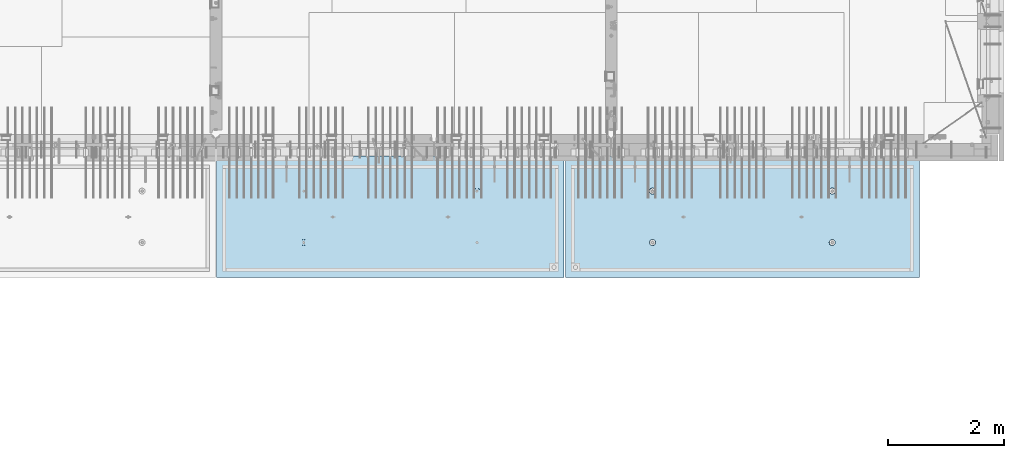
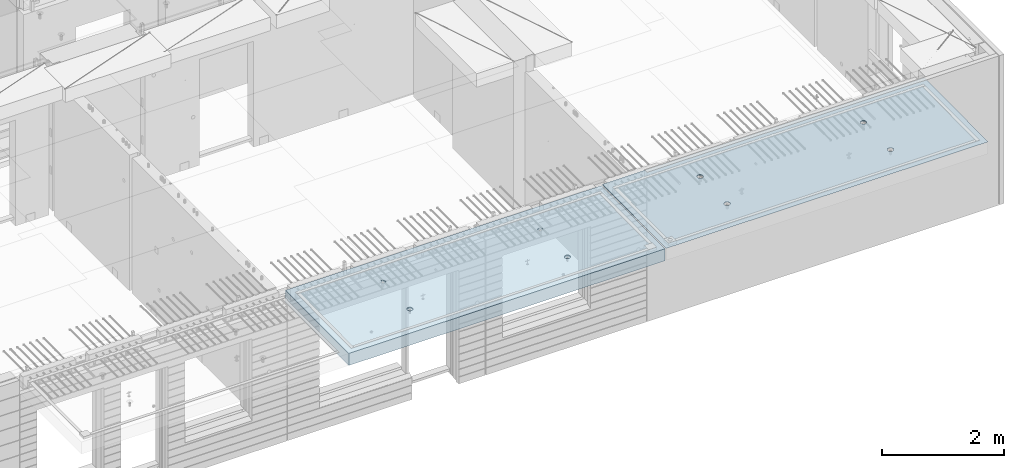
# One storey, part 202 of 349: 2 slabs, 2 elements without a shape of their own.
"""IFC2X3 building model written with IfcOpenShell, lengths in millimetres."""

from ifc_helpers import new_model, si_unit, frame, origin_with_axes, place, context, subcontext, project, spatial, faceted_brep, material, type_object, element, aggregate, save


model = new_model("IFC2X3")

# Units and contexts
model_context = context("Model", 3, precision=1e-05, world=origin_with_axes())
body_context = subcontext(model_context, "Body", "Model", "MODEL_VIEW")
ifc_project = project(units=[si_unit("LENGTHUNIT", "METRE", prefix="MILLI"), si_unit("AREAUNIT", "SQUARE_METRE"), si_unit("VOLUMEUNIT", "CUBIC_METRE"), si_unit("MASSUNIT", "GRAM", prefix="KILO"), si_unit("TIMEUNIT", "SECOND"), si_unit("PLANEANGLEUNIT", "RADIAN"), si_unit("SOLIDANGLEUNIT", "STERADIAN"), si_unit("THERMODYNAMICTEMPERATUREUNIT", "DEGREE_CELSIUS"), si_unit("LUMINOUSINTENSITYUNIT", "LUMEN")], contexts=[model_context])

# Site, building, storey
site_placement = place(None, origin_with_axes())
site = spatial("IfcSite", under=ifc_project, at=site_placement, CompositionType="ELEMENT")
building_placement = place(site_placement, origin_with_axes())
building = spatial("IfcBuilding", under=site, at=building_placement, CompositionType="ELEMENT")
storey_placement = place(building_placement, origin_with_axes())
storey = spatial("IfcBuildingStorey", under=building, at=storey_placement, Name="4", CompositionType="ELEMENT", Elevation=0.0)

# Assembly, slab
assembly_1_placement = place(storey_placement, origin_with_axes())
assembly_1 = element("IfcElementAssembly", 1, at=assembly_1_placement, inside=storey, AssemblyPlace="NOTDEFINED", PredefinedType="REINFORCEMENT_UNIT")
ifc_material = material(Name="CONCRETE/C35/45")
slab_type_1 = type_object("IfcSlabType", PredefinedType="NOTDEFINED")
slab_1_placement = place(assembly_1_placement, frame((33909.9998568133, 7629.99655735226, 93720.0), z_axis=(-1.11800000013248e-06, -0.999999999999375, 0.0), x_axis=(-0.999999999999093, 1.34699999998405e-06, 0.0)))
slab_1 = element("IfcSlab", 2, at=slab_1_placement, type_object=slab_type_1, material=ifc_material, PredefinedType="FLOOR", context=body_context, shape_type="Brep", body=[
    faceted_brep([(4540.5429407651, 4.39872694581572, 1501.06992058926), (4541.14829635528, 10.0, 1500.87322939105), (4548.44394652849, 10.0, 1515.19178906455), (4547.94177529477, 4.5376880098047, 1515.55663695519), (4559.80720044041, 10.0, 1526.55506865745), (4559.44971344555, 4.64790814399021, 1527.04710612474), (4574.1257436257, 10.0, 1533.85075119058), (4573.94028523447, 4.71864591048507, 1534.42153123348), (4589.99797731422, 10.0, 1536.36468442559), (4589.99797663917, 4.74301553473924, 1536.96206902392), (4605.87021668419, 10.0, 1533.85078706184), (4606.05567377324, 4.71864625823218, 1534.42156748629), (4620.18877635769, 10.0, 1526.55513688863), (4620.54626219634, 4.64790880566579, 1527.04717510301), (4631.55205595059, 10.0, 1515.19188297671), (4632.05422627598, 4.53768892097287, 1515.5567319414), (4638.84773848372, 10.0, 1500.87333979142), (4639.45309351355, 4.39872801757883, 1501.0700323201), (4641.36167171873, 10.0, 1485.0011061029), (4642.01569559209, 4.24458991442225, 1485.00110684195), (4638.84777435497, 10.0, 1469.12886673293), (4639.48645790269, 4.09034788147255, 1468.92134666652), (4631.55212418177, 10.0, 1454.81030705943), (4632.10822132771, 3.95111487063696, 1454.40627979329), (4620.18887026985, 10.0, 1443.44702746653), (4620.60028327593, 3.84055859092041, 1442.88076738872), (4605.87032708456, 10.0, 1436.1513449334), (4606.0891136727, 3.76954887632746, 1435.47799164192), (4589.99809339604, 10.0, 1433.63741169839), (4589.99809419923, 3.74507537655882, 1432.92662480936), (4574.12585402606, 10.0, 1436.15130906214), (4573.90706894744, 3.76954852712515, 1435.47795523847), (4559.80729435257, 10.0, 1443.44695923535), (4559.39588258188, 3.84055792690197, 1442.8806981667), (4548.44401475967, 10.0, 1454.81021314727), (4547.88791844284, 3.95111395715503, 1454.40618456334), (4541.14833222653, 10.0, 1469.12875633256), (4540.50964903182, 4.09034680826881, 1468.92123478504), (4538.63439899152, 10.0, 1485.00099002108), (4537.98037499001, 4.24458878673613, 1485.00098928203), (0.0, 10.0, 0.0), (0.0, -10.0, 0.0), (0.000819232023786753, 10.0, 2085.00366210937), (6090.0, 10.0, 1.39971234602854e-09), (6090.0, -10.0, 1.39971234602854e-09), (6090.0009765625, 10.0, 2085.00366210937), (1450.13343574908, -4.39996016312216, 583.805178487186), (1451.68970517172, 10.0, 584.310843019489), (1449.20358093267, 10.0, 600.007498901724), (1447.58488291994, -4.2445425120095, 600.007497072595), (1457.56794425657, -4.54025428339082, 569.17949076172), (1458.90468325205, 10.0, 570.15069079864), (1469.16362510388, -4.65165300057561, 557.566154097598), (1470.14226284945, 10.0, 558.913136598135), (1483.78541952188, -4.72320365252381, 550.106985529351), (1484.30243137612, 10.0, 551.698190519764), (1499.99909477071, -4.74786334385863, 547.536208193364), (1499.99909287695, 10.0, 549.212101755165), (1516.2127641972, -4.72320330067305, 550.107022210277), (1515.69574875919, 10.0, 551.698225994214), (1530.8345417251, -4.65165233150765, 557.566223847243), (1529.85590098004, 10.0, 558.913204074546), (1542.4301962863, -4.54025336292398, 569.179586717545), (1541.09345518054, 10.0, 570.150783671952), (1549.86467170747, -4.39995908172568, 583.805291221456), (1548.30840125891, 10.0, 584.310952198615), (1552.41318790712, -4.24454137573775, 600.00761552858), (1550.79449002351, 10.0, 600.007613699451), (1549.83105300624, -4.08922839167644, 616.199022553535), (1548.30836578447, 10.0, 615.704269581685), (1542.37578967018, -3.94920829200419, 630.796143582923), (1541.09338770413, 10.0, 629.864421802535), (1530.78010888273, -3.83814828256436, 642.374169903326), (1529.85580810672, 10.0, 641.101976003039), (1516.17906941009, -3.76687165064504, 649.804771831361), (1515.69563958006, 10.0, 648.316922081409), (1499.99897631459, -3.74231662515376, 652.364637735232), (1499.99897807923, 10.0, 650.803010846011), (1483.81888899212, -3.76687200104061, 649.804735302227), (1484.30232219699, 10.0, 648.316886606961), (1469.21786628045, -3.83814894927491, 642.374100399286), (1470.14216997614, 10.0, 641.101908526629), (1457.62221161949, -3.94920921009907, 630.796047872702), (1458.90461577564, 10.0, 629.864328929222), (1450.16698124064, -4.08922947161773, 616.198909971055), (1451.68966969727, 10.0, 615.704160402559), (1450.509655854, 4.09040925785666, 1468.92774521603), (1451.1483322995, 10.0, 1469.13526457059), (1448.63439906449, 10.0, 1485.00749825911), (1447.98038215714, 4.24465121529647, 1485.00749752007), (1457.88792425878, 3.95117642574769, 1454.41269697389), (1458.44401483263, 10.0, 1454.8167213853), (1469.39588682837, 3.84062041057041, 1442.8872121491), (1469.80729442553, 10.0, 1443.45346747338), (1483.90707121489, 3.76961102048517, 1435.48447023045), (1484.12585409903, 10.0, 1436.15781730018), (1499.99809427218, 3.74513787325122, 1432.93314014929), (1499.998093469, 10.0, 1433.64391993642), (1516.08911155117, 3.76961136968748, 1435.48450663389), (1515.87032715752, 10.0, 1436.15785317143), (1530.60027917537, 3.8406210745743, 1442.88728137111), (1530.18887034281, 10.0, 1443.45353570456), (1542.1082156577, 3.95117733922962, 1454.41279220383), (1541.55212425473, 10.0, 1454.81681529746), (1549.48645122644, 4.09041033107496, 1468.92785709749), (1548.84777442794, 10.0, 1469.13537497096), (1552.0156885709, 4.24465234298259, 1485.00761507997), (1551.3616717917, 10.0, 1485.00761434093), (1549.45308684185, 4.39879042512621, 1501.07653836665), (1548.84773855669, 10.0, 1500.87984802946), (1542.05422061333, 4.5377513095591, 1515.56323601226), (1541.55205602355, 10.0, 1515.19839121474), (1530.54625810314, 4.64797117923445, 1527.0536776068), (1530.18877643065, 10.0, 1526.56164512666), (1516.05567165627, 4.71870862215292, 1534.42806898436), (1515.87021675715, 10.0, 1533.85729529987), (1499.99797671215, 4.74307789534214, 1536.96857017552), (1499.99797738718, 10.0, 1536.37119266363), (1483.94028749739, 4.71870827439125, 1534.42803273156), (1484.12574369866, 10.0, 1533.85725942862), (1469.44971768469, 4.64797051755886, 1527.05360862854), (1469.80720051337, 10.0, 1526.56157689548), (1457.94178110336, 4.53775039840548, 1515.56314102606), (1458.44394660145, 10.0, 1515.19829730258), (1450.54294758273, 4.39878935334855, 1501.07642663582), (1451.14829642825, 10.0, 1500.87973762909), (4619.85580803376, 10.0, 641.095467765007), (4620.78011297592, -3.83821065611846, 642.367667399533), (4606.17907152706, -3.76693401455123, 649.798270333285), (4605.6956395071, 10.0, 648.310413843377), (4631.09338763116, 10.0, 629.857913564502), (4632.37579533283, -3.94927068060497, 630.789639512066), (4638.30836571149, 10.0, 615.697761343654), (4639.83105967794, -4.08929079922382, 616.192516506986), (4640.79448995054, 10.0, 600.001105461418), (4642.4131949283, -4.24460380429809, 600.001107290555), (4638.30840118594, 10.0, 584.304443960583), (4639.86467838373, -4.40002153132809, 583.798780790478), (4631.09345510758, 10.0, 570.14427543392), (4632.43020195632, -4.54031583151664, 569.173074307006), (4619.85590090707, 10.0, 558.906695836514), (4620.83454582566, -4.65171481517609, 557.559709864858), (4605.69574868622, 10.0, 551.691717756181), (4606.21276631872, -4.72326579401852, 550.100507218302), (4589.99909280399, 10.0, 549.205593517132), (4589.99909469776, -4.74792584055103, 547.529692853434), (4574.30243130315, 10.0, 551.691682281732), (4573.78541725442, -4.72326614588383, 550.10047053737), (4560.14226277649, 10.0, 558.906628360102), (4559.16362085739, -4.65171548424405, 557.559640115202), (4548.90468317908, 10.0, 570.144182560607), (4547.56793844064, -4.54031675198348, 569.172978351166), (4541.68970509875, 10.0, 584.304334781456), (4540.1334289269, -4.40002261272457, 583.798668056191), (4547.6222058109, -3.9492715986853, 630.789543801832), (4559.21786204131, -3.83821132282901, 642.367597895483), (4573.8188867292, -3.76693436496134, 649.798233804147), (4589.99897624161, -3.74237898574211, 652.358136583629), (4537.58487575281, -4.2446049405844, 600.000988834554), (4540.166974423, -4.0892918791651, 616.192403924491), (4589.99897800626, 10.0, 650.796502607977), (4574.30232212402, 10.0, 648.310378368928), (4560.14216990317, 10.0, 641.095400288596), (4548.90461570267, 10.0, 629.85782069119), (4541.6896696243, 10.0, 615.697652164527), (4539.2035808597, 10.0, 600.000990663691)], [[[0, 1, 2, 3]], [[3, 2, 4, 5]], [[5, 4, 6, 7]], [[8, 9, 7, 6]], [[10, 11, 9, 8]], [[12, 13, 11, 10]], [[14, 15, 13, 12]], [[16, 17, 15, 14]], [[18, 19, 17, 16]], [[20, 21, 19, 18]], [[22, 23, 21, 20]], [[24, 25, 23, 22]], [[25, 24, 26, 27]], [[27, 26, 28, 29]], [[29, 28, 30, 31]], [[31, 30, 32, 33]], [[33, 32, 34, 35]], [[35, 34, 36, 37]], [[37, 36, 38, 39]], [[39, 38, 1, 0]], [[40, 41, 42]], [[40, 43, 44, 41]], [[43, 45, 44]], [[46, 47, 48, 49]], [[50, 51, 47, 46]], [[52, 53, 51, 50]], [[54, 55, 53, 52]], [[56, 57, 55, 54]], [[58, 59, 57, 56]], [[59, 58, 60, 61]], [[61, 60, 62, 63]], [[63, 62, 64, 65]], [[65, 64, 66, 67]], [[67, 66, 68, 69]], [[69, 68, 70, 71]], [[71, 70, 72, 73]], [[73, 72, 74, 75]], [[75, 74, 76, 77]], [[78, 79, 77, 76]], [[80, 81, 79, 78]], [[82, 83, 81, 80]], [[84, 85, 83, 82]], [[49, 48, 85, 84]], [[86, 87, 88, 89]], [[90, 91, 87, 86]], [[92, 93, 91, 90]], [[94, 95, 93, 92]], [[96, 97, 95, 94]], [[98, 99, 97, 96]], [[100, 101, 99, 98]], [[101, 100, 102, 103]], [[103, 102, 104, 105]], [[105, 104, 106, 107]], [[107, 106, 108, 109]], [[109, 108, 110, 111]], [[111, 110, 112, 113]], [[113, 112, 114, 115]], [[115, 114, 116, 117]], [[117, 116, 118, 119]], [[120, 121, 119, 118]], [[122, 123, 121, 120]], [[124, 125, 123, 122]], [[89, 88, 125, 124]], [[126, 127, 128, 129]], [[130, 131, 127, 126]], [[132, 133, 131, 130]], [[134, 135, 133, 132]], [[136, 137, 135, 134]], [[138, 139, 137, 136]], [[140, 141, 139, 138]], [[142, 143, 141, 140]], [[143, 142, 144, 145]], [[145, 144, 146, 147]], [[147, 146, 148, 149]], [[149, 148, 150, 151]], [[151, 150, 152, 153]], [[41, 44, 45, 42], [3, 5, 7, 9, 11, 13, 15, 17, 19, 21, 23, 25, 27, 29, 31, 33, 35, 37, 39, 0], [154, 155, 156, 157, 128, 127, 131, 133, 135, 137, 139, 141, 143, 145, 147, 149, 151, 153, 158, 159], [122, 120, 118, 116, 114, 112, 110, 108, 106, 104, 102, 100, 98, 96, 94, 92, 90, 86, 89, 124], [82, 80, 78, 76, 74, 72, 70, 68, 66, 64, 62, 60, 58, 56, 54, 52, 50, 46, 49, 84]], [[129, 128, 157, 160]], [[156, 161, 160, 157]], [[155, 162, 161, 156]], [[154, 163, 162, 155]], [[159, 164, 163, 154]], [[158, 165, 164, 159]], [[153, 152, 165, 158]], [[43, 40, 42, 45], [34, 32, 30, 28, 26, 24, 22, 20, 18, 16, 14, 12, 10, 8, 6, 4, 2, 1, 38, 36], [150, 148, 146, 144, 142, 140, 138, 136, 134, 132, 130, 126, 129, 160, 161, 162, 163, 164, 165, 152], [91, 93, 95, 97, 99, 101, 103, 105, 107, 109, 111, 113, 115, 117, 119, 121, 123, 125, 88, 87], [51, 53, 55, 57, 59, 61, 63, 65, 67, 69, 71, 73, 75, 77, 79, 81, 83, 85, 48, 47]]]),
])
aggregate(assembly_1, [slab_1])

assembly_2_placement = place(storey_placement, origin_with_axes())
assembly_2 = element("IfcElementAssembly", 3, at=assembly_2_placement, inside=storey, AssemblyPlace="NOTDEFINED", PredefinedType="REINFORCEMENT_UNIT")
slab_type_2 = type_object("IfcSlabType", PredefinedType="NOTDEFINED")
slab_2_placement = place(assembly_2_placement, frame((27799.9998568133, 7629.99655735226, 93590.0), z_axis=(-1.11800000013248e-06, -0.999999999999375, 0.0), x_axis=(-0.999999999999093, 1.34699999998405e-06, 0.0)))
slab_2 = element("IfcSlab", 4, at=slab_2_placement, type_object=slab_type_2, material=ifc_material, PredefinedType="FLOOR", context=body_context, shape_type="Brep", body=[
    faceted_brep([(4464.54840508898, -115.0, 647.555217913627), (4450.61000036748, -115.0, 640.453225774507), (4439.54842599525, -115.0, 629.391625938503), (4432.44646594236, -115.0, 615.453204868262), (4429.99930954105, -115.0, 600.002352332828), (4432.44650151022, -115.0, 584.551505430789), (4439.54849364933, -115.0, 570.613100709295), (4450.61009348534, -115.0, 559.551526337066), (4464.54851455558, -115.0, 552.449566284174), (4479.99936709102, -115.0, 550.002409882861), (4495.45021399306, -115.0, 552.449601852029), (4509.38861871455, -115.0, 559.551593991148), (4520.45019308678, -115.0, 570.613193827152), (4527.55215313967, -115.0, 584.551614897394), (4529.99930954098, -115.0, 600.002467432828), (4527.55211757181, -115.0, 615.453314334867), (4520.4501254327, -115.0, 629.39171905636), (4509.38852559669, -115.0, 640.453293428589), (4495.45010452645, -115.0, 647.555253481482), (4479.99925199102, -115.0, 650.002409882794), (4439.08882528693, -120.0, 570.279131286869), (4431.90612869169, -120.0, 584.375926971106), (4450.27612512107, -120.0, 559.091857205865), (4464.37293733984, -120.0, 551.909193061462), (4479.99936774499, -120.0, 549.43422806468), (4495.62579245274, -120.0, 551.909229033498), (4509.72258813697, -120.0, 559.091925628744), (4520.90986221798, -120.0, 570.279225462882), (4528.09252636238, -120.0, 584.37603768165), (4530.56749135916, -120.0, 600.002468086805), (4528.09249039035, -120.0, 615.628892794549), (4520.9097937951, -120.0, 629.725688478787), (4509.72249396096, -120.0, 640.912962559792), (4495.6256817422, -120.0, 648.095626704194), (4479.99925133704, -120.0, 650.570591700976), (4464.3728266293, -120.0, 648.095590732158), (4450.27603094506, -120.0, 640.912894136913), (4439.08875686405, -120.0, 629.725594302773), (4431.90609271965, -120.0, 615.628782084005), (4429.43112772287, -120.0, 600.002351678851), (0.000819232023786753, -120.0, 2085.00366210938), (5980.0009765625, -120.0, 2085.00366210937), (5980.0009765625, 120.0, 2085.00366210937), (0.000819232023786753, 120.0, 2085.00366210938), (5980.0, -120.0, -2.4019755073823e-09), (5980.0, 120.0, -2.4019755073823e-09), (-7.27595761418343e-12, -120.0, -9.09494701772928e-13), (-7.27595761418343e-12, 120.0, -9.09494701772928e-13), (1515.44890870648, -105.0, 1437.44477976918), (1529.38731342797, -105.0, 1444.5467719083), (1540.4488878002, -105.0, 1455.60837174431), (1547.55084785309, -105.0, 1469.54679281455), (1549.99800425441, -105.0, 1484.99764534998), (1547.55081228524, -105.0, 1500.44849225202), (1540.44882014612, -105.0, 1514.38689697351), (1529.38722031012, -105.0, 1525.44847134574), (1515.44879923988, -105.0, 1532.55043139864), (1499.99794670444, -105.0, 1534.99758779995), (1484.5470998024, -105.0, 1532.55039583078), (1470.60869508091, -105.0, 1525.44840369166), (1459.54712070868, -105.0, 1514.38680385566), (1452.44516065579, -105.0, 1500.44838278542), (1449.99800425447, -105.0, 1484.99753024998), (1452.44519622364, -105.0, 1469.54668334794), (1459.54718836276, -105.0, 1455.60827862645), (1470.60878819877, -105.0, 1444.54670425422), (1484.547209269, -105.0, 1437.44474420133), (1499.99806180444, -105.0, 1434.99758780001), (1450.82407776805, -120.0, 1469.01994796889), (1448.29345879993, -120.0, 1484.99752828805), (1458.16818327555, -120.0, 1454.60637035917), (1469.60688310596, -120.0, 1443.16769686061), (1484.02047762178, -120.0, 1435.82362453319), (1499.99806376637, -120.0, 1433.29304234547), (1515.97564408552, -120.0, 1435.82366131359), (1530.38922169525, -120.0, 1443.16776682109), (1541.82789519381, -120.0, 1454.6064666515), (1549.17196752123, -120.0, 1469.02006116732), (1551.70254970895, -120.0, 1484.99764731191), (1549.17193074083, -120.0, 1500.97522763107), (1541.82782523334, -120.0, 1515.38880524079), (1530.38912540293, -120.0, 1526.82747873935), (1515.9755308871, -120.0, 1534.17155106677), (1499.99794474251, -120.0, 1536.70213325449), (1484.02036442336, -120.0, 1534.17151428637), (1469.60678681363, -120.0, 1526.82740877888), (1458.16811331507, -120.0, 1515.38870894846), (1450.82404098765, -120.0, 1500.97511443265), (1484.54840517324, -115.0, 647.55178787166), (1470.61000045175, -115.0, 640.44979573254), (1459.54842607952, -115.0, 629.388195896537), (1452.44646602663, -115.0, 615.449774826296), (1449.99930962532, -115.0, 599.998922290862), (1452.44650159449, -115.0, 584.548075388822), (1459.5484937336, -115.0, 570.609670667329), (1470.61009356961, -115.0, 559.5480962951), (1484.54851463985, -115.0, 552.446136242207), (1499.99936717528, -115.0, 549.998979840894), (1515.45021407733, -115.0, 552.446171810063), (1529.38861879882, -115.0, 559.548163949182), (1540.45019317105, -115.0, 570.609763785185), (1547.55215322394, -115.0, 584.548184855427), (1549.99930962525, -115.0, 599.999037390861), (1547.55211765608, -115.0, 615.449884292901), (1540.45012551697, -115.0, 629.388289014393), (1529.38852568096, -115.0, 640.449863386622), (1515.45010461072, -115.0, 647.551823439516), (1499.99925207528, -115.0, 649.998979840828), (1451.90612877595, -120.0, 584.37249692914), (1449.43112780714, -120.0, 599.998921636884), (1459.0888253712, -120.0, 570.275701244902), (1470.27612520534, -120.0, 559.088427163899), (1484.3729374241, -120.0, 551.905763019496), (1499.99936782926, -120.0, 549.430798022713), (1515.62579253701, -120.0, 551.905798991532), (1529.72258822124, -120.0, 559.088495586778), (1540.90986230225, -120.0, 570.275795420916), (1548.09252644665, -120.0, 584.372607639683), (1550.56749144343, -120.0, 599.999038044839), (1548.09249047462, -120.0, 615.625462752582), (1540.90979387937, -120.0, 629.72225843682), (1529.72249404523, -120.0, 640.909532517825), (1515.62568182647, -120.0, 648.092196662227), (1499.9992514213, -120.0, 650.56716165901), (1484.37282671356, -120.0, 648.092160690191), (1470.27603102933, -120.0, 640.909464094946), (1459.08875694832, -120.0, 629.722164260806), (1451.90609280392, -120.0, 615.625352042039), (4495.44890862221, -105.0, 1437.44820981115), (4509.3873133437, -105.0, 1444.55020195027), (4520.44888771593, -105.0, 1455.61180178627), (4527.55084776882, -105.0, 1469.55022285651), (4529.99800417014, -105.0, 1485.00107539195), (4527.55081220097, -105.0, 1500.45192229399), (4520.44882006185, -105.0, 1514.39032701548), (4509.38722022585, -105.0, 1525.45190138771), (4495.44879915561, -105.0, 1532.5538614406), (4479.99794662017, -105.0, 1535.00101784192), (4464.54709971813, -105.0, 1532.55382587275), (4450.60869499664, -105.0, 1525.45183373363), (4439.54712062441, -105.0, 1514.39023389763), (4432.44516057152, -105.0, 1500.45181282738), (4429.9980041702, -105.0, 1485.00096029195), (4432.44519613937, -105.0, 1469.55011338991), (4439.54718827849, -105.0, 1455.61170866842), (4450.6087881145, -105.0, 1444.55013429619), (4464.54720918474, -105.0, 1437.44817424329), (4479.99806172017, -105.0, 1435.00101784198), (4430.82407768378, -120.0, 1469.02337801086), (4428.29345871566, -120.0, 1485.00095833002), (4438.16818319128, -120.0, 1454.60980040114), (4449.60688302169, -120.0, 1443.17112690258), (4464.02047753751, -120.0, 1435.82705457516), (4479.99806368211, -120.0, 1433.29647238744), (4495.97564400126, -120.0, 1435.82709135556), (4510.38922161098, -120.0, 1443.17119686305), (4521.82789510954, -120.0, 1454.60989669347), (4529.17196743696, -120.0, 1469.02349120928), (4531.70254962468, -120.0, 1485.00107735388), (4529.17193065656, -120.0, 1500.97865767303), (4521.82782514907, -120.0, 1515.39223528276), (4510.38912531866, -120.0, 1526.83090878132), (4495.97553080284, -120.0, 1534.17498110874), (4479.99794465824, -120.0, 1536.70556329646), (4464.02036433909, -120.0, 1534.17494432834), (4449.60678672936, -120.0, 1526.83083882084), (4438.1681132308, -120.0, 1515.39213899043), (4430.82404090338, -120.0, 1500.97854447461)], [[[0, 1, 2, 3, 4, 5, 6, 7, 8, 9, 10, 11, 12, 13, 14, 15, 16, 17, 18, 19]], [[20, 6, 5, 21]], [[22, 7, 6, 20]], [[23, 8, 7, 22]], [[24, 9, 8, 23]], [[25, 10, 9, 24]], [[26, 11, 10, 25]], [[27, 12, 11, 26]], [[28, 13, 12, 27]], [[29, 14, 13, 28]], [[30, 15, 14, 29]], [[31, 16, 15, 30]], [[32, 17, 16, 31]], [[33, 18, 17, 32]], [[34, 19, 18, 33]], [[35, 0, 19, 34]], [[36, 1, 0, 35]], [[37, 2, 1, 36]], [[38, 3, 2, 37]], [[39, 4, 3, 38]], [[21, 5, 4, 39]], [[40, 41, 42, 43]], [[41, 44, 45, 42]], [[44, 46, 47, 45]], [[42, 45, 47, 43]], [[46, 40, 43, 47]], [[48, 49, 50, 51, 52, 53, 54, 55, 56, 57, 58, 59, 60, 61, 62, 63, 64, 65, 66, 67]], [[68, 63, 62, 69]], [[70, 64, 63, 68]], [[71, 65, 64, 70]], [[72, 66, 65, 71]], [[73, 67, 66, 72]], [[74, 48, 67, 73]], [[75, 49, 48, 74]], [[76, 50, 49, 75]], [[77, 51, 50, 76]], [[78, 52, 51, 77]], [[79, 53, 52, 78]], [[80, 54, 53, 79]], [[81, 55, 54, 80]], [[82, 56, 55, 81]], [[83, 57, 56, 82]], [[84, 58, 57, 83]], [[85, 59, 58, 84]], [[86, 60, 59, 85]], [[87, 61, 60, 86]], [[69, 62, 61, 87]], [[88, 89, 90, 91, 92, 93, 94, 95, 96, 97, 98, 99, 100, 101, 102, 103, 104, 105, 106, 107]], [[108, 93, 92, 109]], [[110, 94, 93, 108]], [[111, 95, 94, 110]], [[112, 96, 95, 111]], [[113, 97, 96, 112]], [[114, 98, 97, 113]], [[115, 99, 98, 114]], [[116, 100, 99, 115]], [[117, 101, 100, 116]], [[118, 102, 101, 117]], [[119, 103, 102, 118]], [[120, 104, 103, 119]], [[121, 105, 104, 120]], [[122, 106, 105, 121]], [[123, 107, 106, 122]], [[124, 88, 107, 123]], [[125, 89, 88, 124]], [[126, 90, 89, 125]], [[127, 91, 90, 126]], [[109, 92, 91, 127]], [[128, 129, 130, 131, 132, 133, 134, 135, 136, 137, 138, 139, 140, 141, 142, 143, 144, 145, 146, 147]], [[148, 143, 142, 149]], [[150, 144, 143, 148]], [[151, 145, 144, 150]], [[152, 146, 145, 151]], [[153, 147, 146, 152]], [[154, 128, 147, 153]], [[155, 129, 128, 154]], [[156, 130, 129, 155]], [[157, 131, 130, 156]], [[158, 132, 131, 157]], [[159, 133, 132, 158]], [[160, 134, 133, 159]], [[161, 135, 134, 160]], [[162, 136, 135, 161]], [[163, 137, 136, 162]], [[164, 138, 137, 163]], [[165, 139, 138, 164]], [[166, 140, 139, 165]], [[167, 141, 140, 166]], [[149, 142, 141, 167]], [[44, 41, 40, 46], [37, 36, 35, 34, 33, 32, 31, 30, 29, 28, 27, 26, 25, 24, 23, 22, 20, 21, 39, 38], [166, 165, 164, 163, 162, 161, 160, 159, 158, 157, 156, 155, 154, 153, 152, 151, 150, 148, 149, 167], [126, 125, 124, 123, 122, 121, 120, 119, 118, 117, 116, 115, 114, 113, 112, 111, 110, 108, 109, 127], [86, 85, 84, 83, 82, 81, 80, 79, 78, 77, 76, 75, 74, 73, 72, 71, 70, 68, 69, 87]]]),
])
aggregate(assembly_2, [slab_2])

save(model, "model.ifc")
